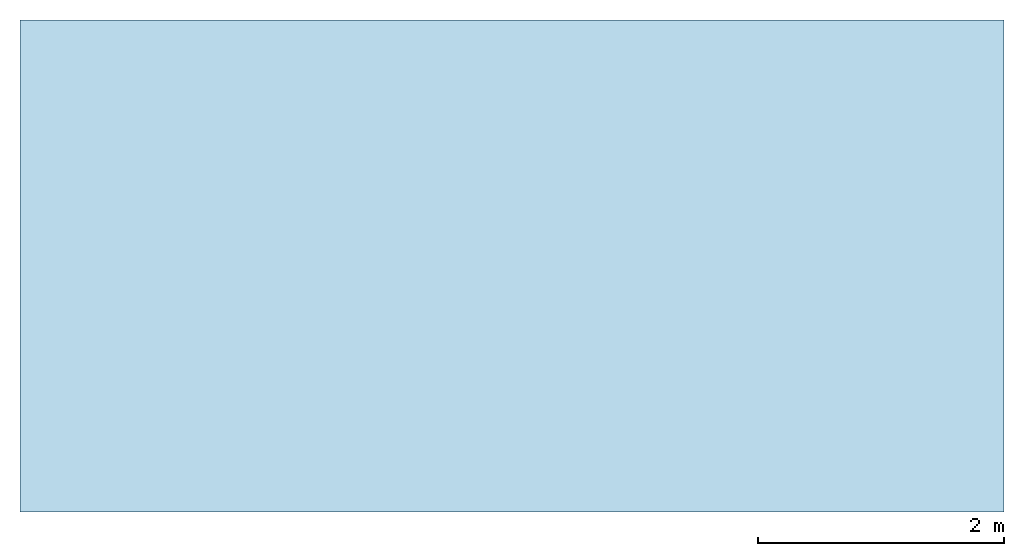
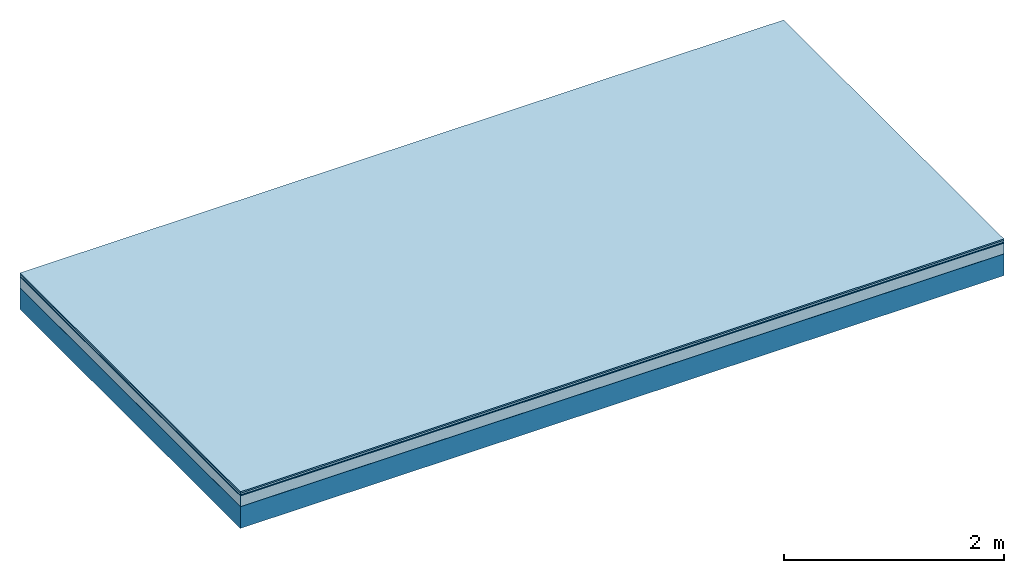
# One storey: 5 plates, 1 member, 1 element without a shape of its own.
"""IFC4 building model written with IfcOpenShell, lengths in metres."""

from ifc_helpers import new_model, si_unit, derived_unit, direction, frame, frame_2d, origin, origin_with_axes, place, context, project, spatial, rectangle, extrude, material, layer, layer_set, type_object, element, aggregate, save


model = new_model("IFC4")

# Units and contexts
plan_context = context("Plan", 3, precision=1e-05, world=origin(), true_north=direction((0.0, 1.0)))
model_context = context("Model", 3, precision=1e-05, world=origin(), true_north=direction((0.0, 1.0)))
ifc_project = project(units=[si_unit("LENGTHUNIT", "METRE"), derived_unit("SOUNDPRESSUREUNIT", [(si_unit("PRESSUREUNIT", "PASCAL", prefix="MICRO"), 0)]), si_unit("ENERGYUNIT", "JOULE", prefix="MEGA"), si_unit("MASSUNIT", "GRAM", prefix="KILO"), derived_unit("THERMALTRANSMITTANCEUNIT", [(si_unit("POWERUNIT", "WATT"), 1), (si_unit("AREAUNIT", "SQUARE_METRE"), -1), (si_unit("THERMODYNAMICTEMPERATUREUNIT", "KELVIN"), -1)]), derived_unit("AREADENSITYUNIT", [(si_unit("MASSUNIT", "GRAM", prefix="KILO"), 1), (si_unit("AREAUNIT", "SQUARE_METRE"), -1)]), derived_unit("USERDEFINED", [(si_unit("ENERGYUNIT", "JOULE", prefix="MEGA"), 1), (si_unit("AREAUNIT", "SQUARE_METRE"), -1)])], contexts=[plan_context, model_context])

# Site, building, storey
site = spatial("IfcSite", under=ifc_project)
building_placement = place(None, origin())
building = spatial("IfcBuilding", under=site, at=building_placement)
storey_placement = place(building_placement, origin())
storey = spatial("IfcBuildingStorey", under=building, at=storey_placement)

# Slab, member, plates
ifc_material_1 = material(Category="11.013")
ifc_layer_1 = layer(ifc_material_1, 0.015, Name="Flooring")
ifc_material_2 = material(Category="03.007")
ifc_layer_2 = layer(ifc_material_2, 0.02, Name="On-material")
ifc_material_3 = material(Name="Wood fiber generic product", Category="10.009")
ifc_layer_3 = layer(ifc_material_3, 0.01, Name="Impact sound insulation")
ifc_material_4 = material(Category="03.011")
ifc_layer_4 = layer(ifc_material_4, 0.12, Name="on Supporting structure")
ifc_material_5 = material(Name="protection", Category="09.007")
ifc_layer_5 = layer(ifc_material_5, 0.0005, Name="Sub-floor")
ifc_material_6 = material(Name="no composite action")
ifc_layer_6 = layer(ifc_material_6, 0.0, Name="Bond")
ifc_layer_7 = layer(None, 0.24, Name="Supporting structure")
ifc_layer_set = layer_set([ifc_layer_1, ifc_layer_2, ifc_layer_3, ifc_layer_4, ifc_layer_5, ifc_layer_6, ifc_layer_7])
slab_type = type_object("IfcSlabType", Name="A2057", PredefinedType="NOTDEFINED", material=ifc_layer_set)
slab_placement = place(None, frame((0.0, 0.0, 0.0), z_axis=(0.0, 0.0, -1.0), x_axis=(1.0, 0.0, 0.0)))
slab = element("IfcSlab", 1, at=slab_placement, inside=storey, type_object=slab_type, material=ifc_layer_set, Name="Slab #1")
ifc_material_7 = material(Name="Solid timber panel")
member_placement = place(slab_placement, origin())
member = element("IfcMember", 2, at=member_placement, material=ifc_material_7, Name="Supporting structure", context=plan_context, shape_type="SweptSolid", body=[
    extrude(rectangle(XDim=1.0, YDim=0.24, at=frame_2d((0.5, 0.12), x_axis=(1.0, 0.0))), frame((0.0, 4.0, 0.1655), z_axis=(0.0, -1.0, 0.0), x_axis=(1.0, 0.0, 0.0)), (0.0, 0.0, 1.0), 4.0),
    extrude(rectangle(XDim=1.0, YDim=0.24, at=frame_2d((0.5, 0.12), x_axis=(1.0, 0.0))), frame((1.0, 4.0, 0.1655), z_axis=(0.0, -1.0, 0.0), x_axis=(1.0, 0.0, 0.0)), (0.0, 0.0, 1.0), 4.0),
    extrude(rectangle(XDim=1.0, YDim=0.24, at=frame_2d((0.5, 0.12), x_axis=(1.0, 0.0))), frame((2.0, 4.0, 0.1655), z_axis=(0.0, -1.0, 0.0), x_axis=(1.0, 0.0, 0.0)), (0.0, 0.0, 1.0), 4.0),
    extrude(rectangle(XDim=1.0, YDim=0.24, at=frame_2d((0.5, 0.12), x_axis=(1.0, 0.0))), frame((3.0, 4.0, 0.1655), z_axis=(0.0, -1.0, 0.0), x_axis=(1.0, 0.0, 0.0)), (0.0, 0.0, 1.0), 4.0),
    extrude(rectangle(XDim=1.0, YDim=0.24, at=frame_2d((0.5, 0.12), x_axis=(1.0, 0.0))), frame((4.0, 4.0, 0.1655), z_axis=(0.0, -1.0, 0.0), x_axis=(1.0, 0.0, 0.0)), (0.0, 0.0, 1.0), 4.0),
    extrude(rectangle(XDim=1.0, YDim=0.24, at=frame_2d((0.5, 0.12), x_axis=(1.0, 0.0))), frame((5.0, 4.0, 0.1655), z_axis=(0.0, -1.0, 0.0), x_axis=(1.0, 0.0, 0.0)), (0.0, 0.0, 1.0), 4.0),
    extrude(rectangle(XDim=1.0, YDim=0.24, at=frame_2d((0.5, 0.12), x_axis=(1.0, 0.0))), frame((6.0, 4.0, 0.1655), z_axis=(0.0, -1.0, 0.0), x_axis=(1.0, 0.0, 0.0)), (0.0, 0.0, 1.0), 4.0),
    extrude(rectangle(XDim=1.0, YDim=0.24, at=frame_2d((0.5, 0.12), x_axis=(1.0, 0.0))), frame((7.0, 4.0, 0.1655), z_axis=(0.0, -1.0, 0.0), x_axis=(1.0, 0.0, 0.0)), (0.0, 0.0, 1.0), 4.0),
])
plate_1_placement = place(slab_placement, origin())
plate_1 = element("IfcPlate", 3, at=plate_1_placement, material=ifc_material_1, Name="Flooring", context=plan_context, shape_type="SweptSolid", body=[
    extrude(rectangle(XDim=8.0, YDim=4.0, at=frame_2d((4.0, 2.0), x_axis=(1.0, 0.0))), origin_with_axes(), (0.0, 0.0, 1.0), 0.015),
])
plate_2_placement = place(slab_placement, origin())
plate_2 = element("IfcPlate", 4, at=plate_2_placement, material=ifc_material_2, Name="On-material", context=plan_context, shape_type="SweptSolid", body=[
    extrude(rectangle(XDim=8.0, YDim=4.0, at=frame_2d((4.0, 2.0), x_axis=(1.0, 0.0))), frame((0.0, 0.0, 0.015), z_axis=(0.0, 0.0, 1.0), x_axis=(1.0, 0.0, 0.0)), (0.0, 0.0, 1.0), 0.02),
])
plate_3_placement = place(slab_placement, origin())
plate_3 = element("IfcPlate", 5, at=plate_3_placement, material=ifc_material_3, Name="Impact sound insulation", context=plan_context, shape_type="SweptSolid", body=[
    extrude(rectangle(XDim=8.0, YDim=4.0, at=frame_2d((4.0, 2.0), x_axis=(1.0, 0.0))), frame((0.0, 0.0, 0.035), z_axis=(0.0, 0.0, 1.0), x_axis=(1.0, 0.0, 0.0)), (0.0, 0.0, 1.0), 0.01),
])
plate_4_placement = place(slab_placement, origin())
plate_4 = element("IfcPlate", 6, at=plate_4_placement, material=ifc_material_4, Name="on Supporting structure", context=plan_context, shape_type="SweptSolid", body=[
    extrude(rectangle(XDim=8.0, YDim=4.0, at=frame_2d((4.0, 2.0), x_axis=(1.0, 0.0))), frame((0.0, 0.0, 0.045), z_axis=(0.0, 0.0, 1.0), x_axis=(1.0, 0.0, 0.0)), (0.0, 0.0, 1.0), 0.12),
])
plate_5_placement = place(slab_placement, origin())
plate_5 = element("IfcPlate", 7, at=plate_5_placement, material=ifc_material_5, Name="Sub-floor", context=plan_context, shape_type="SweptSolid", body=[
    extrude(rectangle(XDim=8.0, YDim=4.0, at=frame_2d((4.0, 2.0), x_axis=(1.0, 0.0))), frame((0.0, 0.0, 0.165), z_axis=(0.0, 0.0, 1.0), x_axis=(1.0, 0.0, 0.0)), (0.0, 0.0, 1.0), 0.0005),
])
aggregate(slab, [plate_1, plate_2, plate_3, plate_4, plate_5, member])

save(model, "model.ifc")
